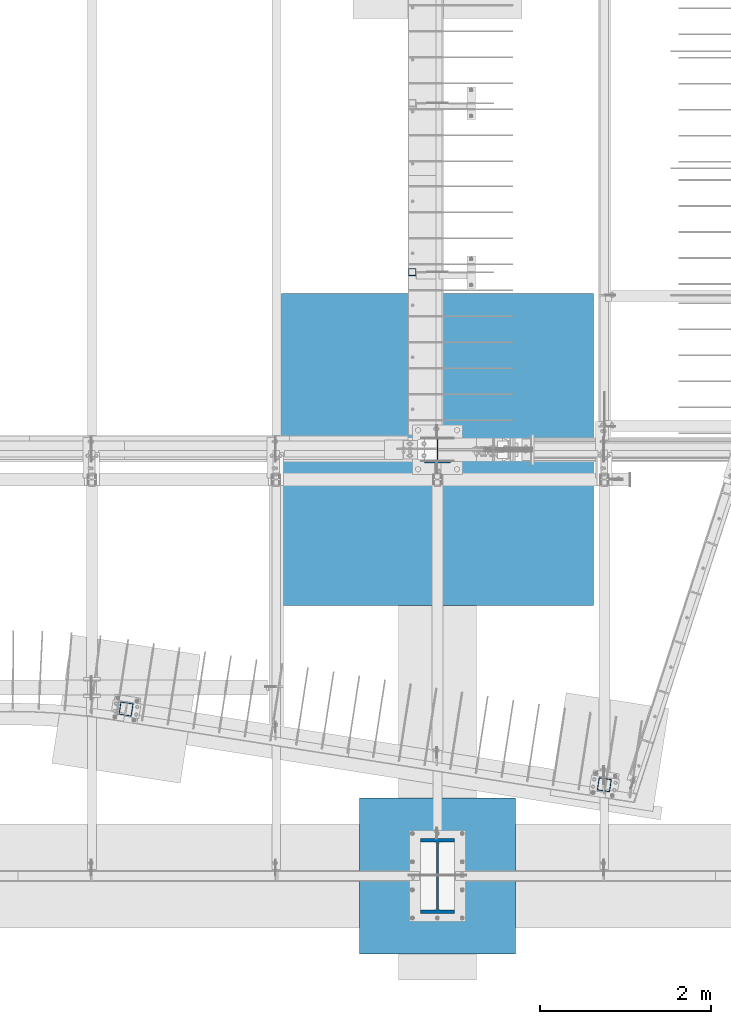
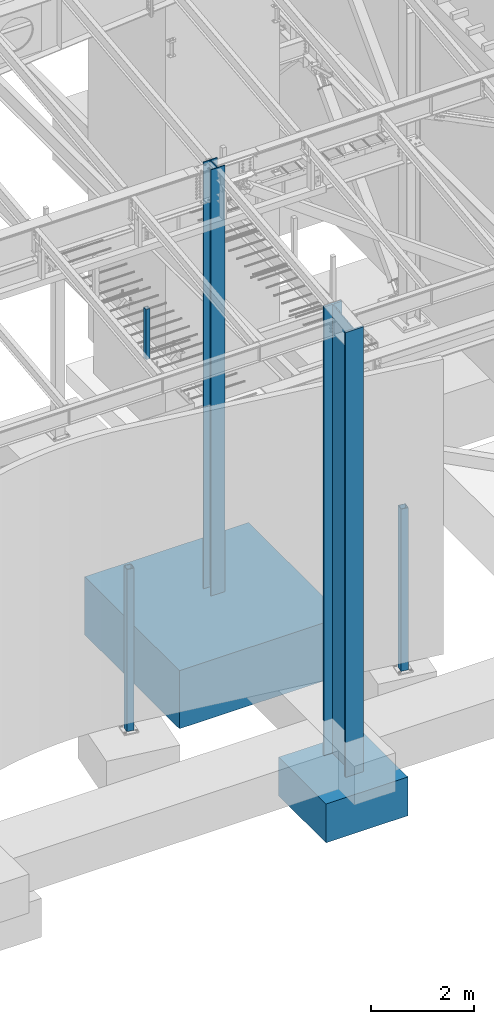
# One storey, part 353 of 1179: 7 columns, 7 elements without a shape of their own.
"""IFC2X3 building model written with IfcOpenShell, lengths in millimetres."""

from ifc_helpers import new_model, si_unit, frame, origin_with_axes, place, context, subcontext, project, spatial, faceted_brep, material, type_object, element, aggregate, save


model = new_model("IFC2X3")

# Units and contexts
model_context = context("Model", 3, precision=1e-05, world=origin_with_axes())
body_context = subcontext(model_context, "Body", "Model", "MODEL_VIEW")
ifc_project = project(units=[si_unit("LENGTHUNIT", "METRE", prefix="MILLI"), si_unit("AREAUNIT", "SQUARE_METRE"), si_unit("VOLUMEUNIT", "CUBIC_METRE"), si_unit("MASSUNIT", "GRAM", prefix="KILO"), si_unit("TIMEUNIT", "SECOND"), si_unit("PLANEANGLEUNIT", "RADIAN"), si_unit("SOLIDANGLEUNIT", "STERADIAN"), si_unit("THERMODYNAMICTEMPERATUREUNIT", "DEGREE_CELSIUS"), si_unit("LUMINOUSINTENSITYUNIT", "LUMEN")], contexts=[model_context])

# Site, building, storey
site_placement = place(None, origin_with_axes())
site = spatial("IfcSite", under=ifc_project, at=site_placement, CompositionType="ELEMENT")
building_placement = place(site_placement, origin_with_axes())
building = spatial("IfcBuilding", under=site, at=building_placement, Name="Undefined", CompositionType="ELEMENT")
storey_placement = place(building_placement, origin_with_axes())
storey = spatial("IfcBuildingStorey", under=building, at=storey_placement, Name="Undefined", CompositionType="ELEMENT", Elevation=0.0)

# Assembly, column
assembly_1_placement = place(storey_placement, origin_with_axes())
assembly_1 = element("IfcElementAssembly", 1, at=assembly_1_placement, inside=storey, Name="COLUMN", AssemblyPlace="NOTDEFINED", PredefinedType="RIGID_FRAME")
ifc_material_1 = material()
column_type_1 = type_object("IfcColumnType", Name="HSS6X6X3/8", PredefinedType="NOTDEFINED")
column_1_placement = place(assembly_1_placement, frame((18414.9999999967, 1508.125, -431.8), z_axis=(0.154376895068654, 0.988012031439376, 0.0), x_axis=(0.0, 0.0, 1.0)))
column_1 = element("IfcColumn", 2, at=column_1_placement, type_object=column_type_1, material=ifc_material_1, Name="COLUMN", ObjectType="HSS6X6X3/8", context=body_context, shape_type="Brep", body=[
    faceted_brep([(76.2000000000008, 66.675000000112, -66.6749999999902), (76.2000000000008, -66.6750000001084, -66.6750000000175), (3902.075, -66.6750000001084, -66.6750000000175), (3902.075, 66.675000000112, -66.6749999999902), (76.2000000000008, -66.6750000001011, 66.674999999992), (3902.075, -66.6750000001011, 66.674999999992), (76.2000000000008, 66.6750000001193, 66.6750000000193), (3902.075, 66.6750000001193, 66.6750000000193), (76.2000000000008, 76.2000000001281, -76.1999999999898), (76.2000000000008, 76.2000000001317, 76.2000000000216), (3902.075, 76.2000000001317, 76.2000000000216), (3902.075, 76.2000000001281, -76.1999999999898), (76.2000000000008, -76.2000000001171, 76.1999999999916), (3902.075, -76.2000000001171, 76.1999999999916), (76.2000000000008, -76.2000000001208, -76.2000000000198), (3902.075, -76.2000000001208, -76.2000000000198)], [[[0, 1, 2, 3]], [[1, 4, 5, 2]], [[4, 6, 7, 5]], [[6, 0, 3, 7]], [[8, 9, 10, 11]], [[9, 12, 13, 10]], [[12, 14, 15, 13]], [[14, 8, 11, 15]], [[13, 15, 11, 10], [5, 7, 3, 2]], [[14, 12, 9, 8], [6, 4, 1, 0]]]),
])
aggregate(assembly_1, [column_1])

assembly_2_placement = place(storey_placement, origin_with_axes())
assembly_2 = element("IfcElementAssembly", 3, at=assembly_2_placement, inside=storey, Name="COLUMN", AssemblyPlace="NOTDEFINED", PredefinedType="RIGID_FRAME")
column_2_placement = place(assembly_2_placement, frame((12807.7262148692, 2395.53442645032, -431.8), z_axis=(0.154376895068654, 0.988012031439376, 0.0), x_axis=(0.0, 0.0, 1.0)))
column_2 = element("IfcColumn", 4, at=column_2_placement, type_object=column_type_1, material=ifc_material_1, Name="COLUMN", ObjectType="HSS6X6X3/8", context=body_context, shape_type="Brep", body=[
    faceted_brep([(76.2000000000008, 66.675000000112, -66.6749999999902), (76.2000000000008, -66.6750000001084, -66.6750000000175), (3902.075, -66.6750000001084, -66.6750000000175), (3902.075, 66.675000000112, -66.6749999999902), (76.2000000000008, -66.6750000001011, 66.674999999992), (3902.075, -66.6750000001011, 66.674999999992), (76.2000000000008, 66.6750000001193, 66.6750000000193), (3902.075, 66.6750000001193, 66.6750000000193), (76.2000000000008, 76.2000000001281, -76.1999999999898), (76.2000000000008, 76.2000000001317, 76.2000000000216), (3902.075, 76.2000000001317, 76.2000000000216), (3902.075, 76.2000000001281, -76.1999999999898), (76.2000000000008, -76.2000000001171, 76.1999999999916), (3902.075, -76.2000000001171, 76.1999999999916), (76.2000000000008, -76.2000000001208, -76.2000000000198), (3902.075, -76.2000000001208, -76.2000000000198)], [[[0, 1, 2, 3]], [[1, 4, 5, 2]], [[4, 6, 7, 5]], [[6, 0, 3, 7]], [[8, 9, 10, 11]], [[9, 12, 13, 10]], [[12, 14, 15, 13]], [[14, 8, 11, 15]], [[13, 15, 11, 10], [5, 7, 3, 2]], [[14, 12, 9, 8], [6, 4, 1, 0]]]),
])
aggregate(assembly_2, [column_2])

assembly_3_placement = place(storey_placement, origin_with_axes())
assembly_3 = element("IfcElementAssembly", 5, at=assembly_3_placement, inside=storey, Name="COLUMN", AssemblyPlace="NOTDEFINED", PredefinedType="RIGID_FRAME")
column_type_2 = type_object("IfcColumnType", Name="HSS3-1/2X3-1/2X5/16", PredefinedType="NOTDEFINED")
column_3_placement = place(assembly_3_placement, frame((16163.925, 7518.40000000001, 4108.45000000003), z_axis=(0.0, 1.0, 0.0), x_axis=(0.0, 0.0, 1.0)))
column_3 = element("IfcColumn", 6, at=column_3_placement, type_object=column_type_2, material=ifc_material_1, Name="COLUMN", ObjectType="HSS3-1/2X3-1/2X5/16", context=body_context, shape_type="Brep", body=[
    faceted_brep([(0.0, 36.5125000000007, -36.5125000000007), (0.0, -36.5125000000007, -36.5125000000007), (1189.03749999998, -36.5125000000007, -36.5124999999998), (1189.03749999998, 36.5125000000007, -36.5124999999998), (0.0, -36.5125000000007, 36.5125000000007), (1189.03749999998, -36.5125000000007, 36.5124999999998), (0.0, 36.5125000000007, 36.5125000000007), (1189.03749999998, 36.5125000000007, 36.5124999999998), (0.0, 44.4500000000007, -44.4499999999998), (0.0, 44.4500000000007, 44.4500000000007), (1189.03749999998, 44.4500000000007, 44.4499999999998), (1189.03749999998, 44.4500000000007, -44.4499999999998), (0.0, -44.4500000000007, 44.4500000000007), (1189.03749999998, -44.4500000000007, 44.4499999999998), (0.0, -44.4500000000007, -44.4500000000007), (1189.03749999998, -44.4500000000007, -44.4499999999998)], [[[0, 1, 2, 3]], [[1, 4, 5, 2]], [[4, 6, 7, 5]], [[6, 0, 3, 7]], [[8, 9, 10, 11]], [[9, 12, 13, 10]], [[12, 14, 15, 13]], [[14, 8, 11, 15]], [[13, 15, 11, 10], [5, 7, 3, 2]], [[14, 12, 9, 8], [6, 4, 1, 0]]]),
])
aggregate(assembly_3, [column_3])

assembly_4_placement = place(storey_placement, origin_with_axes())
assembly_4 = element("IfcElementAssembly", 7, at=assembly_4_placement, inside=storey, Name="FOOTING", AssemblyPlace="NOTDEFINED", PredefinedType="REINFORCEMENT_UNIT")
ifc_material_2 = material(Name="CONCRETE/3000")
column_type_3 = type_object("IfcColumnType", PredefinedType="NOTDEFINED")
column_4_placement = place(assembly_4_placement, frame((16459.2, 438.15, -2260.6), z_axis=(-1.0, 0.0, 0.0), x_axis=(0.0, 0.0, 1.0)))
column_4 = element("IfcColumn", 8, at=column_4_placement, type_object=column_type_3, material=ifc_material_2, Name="FOOTING", context=body_context, shape_type="Brep", body=[
    faceted_brep([(0.0, 914.400000000001, -914.400000000001), (0.0, 914.400000000001, 914.400000000001), (914.4, 914.4, 914.400000000001), (914.4, 914.4, -914.400000000001), (0.0, -914.400000000001, 914.400000000001), (914.4, -914.4, 914.400000000001), (0.0, -914.400000000001, -914.400000000001), (914.4, -914.4, -914.400000000001)], [[[0, 1, 2, 3]], [[1, 4, 5, 2]], [[4, 6, 7, 5]], [[6, 0, 3, 7]], [[5, 7, 3, 2]], [[6, 4, 1, 0]]]),
])
aggregate(assembly_4, [column_4])

assembly_5_placement = place(storey_placement, origin_with_axes())
assembly_5 = element("IfcElementAssembly", 9, at=assembly_5_placement, inside=storey, Name="FOOTING", AssemblyPlace="NOTDEFINED", PredefinedType="REINFORCEMENT_UNIT")
column_type_4 = type_object("IfcColumnType", PredefinedType="NOTDEFINED")
column_5_placement = place(assembly_5_placement, frame((16459.2, 5435.6, -1727.2), z_axis=(-1.0, 0.0, 0.0), x_axis=(0.0, 0.0, 1.0)))
column_5 = element("IfcColumn", 10, at=column_5_placement, type_object=column_type_4, material=ifc_material_2, Name="FOOTING", context=body_context, shape_type="Brep", body=[
    faceted_brep([(0.0, 1828.8, -1828.8), (0.0, 1828.8, 1828.8), (1371.6, 1828.8, 1828.8), (1371.6, 1828.8, -1828.8), (0.0, -1828.8, 1828.8), (1371.6, -1828.8, 1828.8), (0.0, -1828.8, -1828.8), (1371.6, -1828.8, -1828.8)], [[[0, 1, 2, 3]], [[1, 4, 5, 2]], [[4, 6, 7, 5]], [[6, 0, 3, 7]], [[5, 7, 3, 2]], [[6, 4, 1, 0]]]),
])
aggregate(assembly_5, [column_5])

assembly_6_placement = place(storey_placement, origin_with_axes())
assembly_6 = element("IfcElementAssembly", 11, at=assembly_6_placement, inside=storey, Name="COLUMN", AssemblyPlace="NOTDEFINED", PredefinedType="RIGID_FRAME")
ifc_material_3 = material(Name="STEEL/A992")
column_type_5 = type_object("IfcColumnType", Name="W33X263", PredefinedType="NOTDEFINED")
column_6_placement = place(assembly_6_placement, frame((16459.2, 438.15, -1346.2), z_axis=(0.0, 1.0, 0.0), x_axis=(0.0, 0.0, 1.0)))
column_6 = element("IfcColumn", 12, at=column_6_placement, type_object=column_type_5, material=ifc_material_3, Name="COLUMN", ObjectType="W33X263", context=body_context, shape_type="Brep", body=[
    faceted_brep([(88.8999999999999, 200.025000000001, -438.15), (88.8999999999999, 200.025000000001, -398.4625), (10587.9886488325, 200.025000000001, -398.4625), (10583.5040139534, 200.025000000001, -438.15), (88.8999999999999, 11.1124999999993, -398.4625), (10587.9886488325, 11.1124999999993, -398.4625), (88.8999999999999, 11.1124999999993, 398.4625), (10678.0401172034, 11.1124999999993, 398.4625), (88.8999999999999, 200.025000000001, 398.4625), (10678.0401172034, 200.025000000001, 398.4625), (88.8999999999999, 200.025000000001, 438.15), (10682.5247520824, 200.025000000001, 438.15), (88.8999999999999, -200.025000000001, 438.15), (10682.5247520824, -200.025000000001, 438.15), (88.8999999999999, -200.025000000001, 398.4625), (10678.0401172034, -200.025000000001, 398.4625), (88.8999999999999, -11.1124999999993, 398.4625), (10678.0401172034, -11.1124999999993, 398.4625), (88.8999999999999, -11.1124999999993, -398.4625), (10587.9886488325, -11.1124999999993, -398.4625), (88.8999999999999, -200.025000000001, -398.4625), (10587.9886488325, -200.025000000001, -398.4625), (88.8999999999999, -200.025000000001, -438.15), (10583.5040139534, -200.025000000001, -438.15)], [[[0, 1, 2, 3]], [[1, 4, 5, 2]], [[4, 6, 7, 5]], [[6, 8, 9, 7]], [[8, 10, 11, 9]], [[10, 12, 13, 11]], [[12, 14, 15, 13]], [[14, 16, 17, 15]], [[16, 18, 19, 17]], [[18, 20, 21, 19]], [[20, 22, 23, 21]], [[22, 0, 3, 23]], [[5, 7, 9, 11, 13, 15, 17, 19, 21, 23, 3, 2]], [[22, 20, 18, 16, 14, 12, 10, 8, 6, 4, 1, 0]]]),
])
aggregate(assembly_6, [column_6])

assembly_7_placement = place(storey_placement, origin_with_axes())
assembly_7 = element("IfcElementAssembly", 13, at=assembly_7_placement, inside=storey, Name="COLUMN", AssemblyPlace="NOTDEFINED", PredefinedType="RIGID_FRAME")
column_type_6 = type_object("IfcColumnType", Name="W12X79", PredefinedType="NOTDEFINED")
column_7_placement = place(assembly_7_placement, frame((16459.2, 5435.6, -355.6), z_axis=(0.0, 1.0, 0.0), x_axis=(0.0, 0.0, 1.0)))
column_7 = element("IfcColumn", 14, at=column_7_placement, type_object=column_type_6, material=ifc_material_3, Name="COLUMN", ObjectType="W12X79", context=body_context, shape_type="Brep", body=[
    faceted_brep([(160.223581529497, -153.987499999999, 157.1625), (160.223581529497, 153.987499999999, 157.1625), (149.225002356772, 153.987499999999, 138.1125), (149.225002356772, 6.35000012494493, 138.1125), (148.995793121516, 6.35000012313685, 137.715499999996), (148.995793121516, -6.34999999999854, 137.715499999996), (149.225002356772, -6.34999999999854, 138.1125), (149.225002356772, -153.987499999999, 138.1125), (10216.753125, 153.987499999999, -157.1625), (10216.753125, -153.987499999999, -157.1625), (160.223597538519, -153.987499999999, -157.1625), (160.223597538519, 153.987499999999, -157.1625), (10216.753125, -153.987499999999, -138.1125), (149.225402461476, -153.987499999999, -138.1125), (10216.753125, -6.34999999999854, -138.1125), (149.225402461476, -6.34999999999854, -138.1125), (188.913, -6.34999999999854, 137.715499999996), (188.913, 6.35000008947463, 137.715499999996), (208.49066058208, 6.35000008789211, 131.2871410688), (208.49066058208, -6.34999999999854, 131.2871410688), (212.873373738864, 6.35000008718271, 128.290736246858), (212.873373738864, -6.34999999999854, 128.290736246858), (214.971292158606, 6.35000008606585, 123.413713099926), (214.971292158606, -6.34999999999854, 123.413713099926), (214.132634973196, 6.3500000848835, 118.171264187733), (214.132634973196, -6.34999999999854, 118.171264187733), (210.617956026487, 6.35000008400311, 114.192112472459), (210.617956026487, -6.34999999999854, 114.192112472459), (205.519195059062, 6.35000008370116, 112.712499999996), (205.519195059062, -6.34999999999854, 112.712499999996), (139.700000000001, 6.34999999999854, 112.7125), (147.032309983244, -6.35000007376584, 112.7125), (139.700000000001, 6.34999999999854, -112.7125), (147.032309983244, -6.35000000747095, -112.7125), (205.519195059063, 6.3500000365857, -112.712500000003), (205.519195059063, -6.34999999999854, -112.712500000003), (210.617956026486, 6.35000003621826, -114.192112472468), (210.617956026486, -6.34999999999854, -114.192112472468), (214.132634973195, 6.35000003529422, -118.171264187741), (214.132634973195, -6.34999999999854, -118.171264187741), (214.971292158605, 6.35000003410096, -123.413713099934), (214.971292158605, -6.34999999999854, -123.413713099934), (212.873373738863, 6.35000003300956, -128.290736246865), (212.873373738863, -6.34999999999854, -128.290736246865), (208.49066058208, 6.35000003235837, -131.287141068808), (208.49066058208, -6.34999999999854, -131.287141068808), (188.913, 6.35000003102323, -137.715500000003), (188.913, -6.34999999999854, -137.715500000003), (148.99620123074, 6.35000000162472, -137.715500000003), (148.99620123074, -6.34999999999854, -137.715500000003), (10216.753125, 6.34999999999854, -138.1125), (10216.753125, 153.987499999999, -138.1125), (149.225402461476, 153.987499999999, -138.1125), (149.225402461477, 6.34999999999854, -138.1125), (10216.753125, 6.34999999999854, 138.1125), (10216.753125, 153.987499999999, 138.1125), (10216.753125, 153.987499999999, 157.1625), (10216.753125, -153.987499999999, 157.1625), (10216.753125, -153.987499999999, 138.1125), (10216.753125, -6.34999999999854, 138.1125)], [[[0, 1, 2, 3, 4, 5, 6, 7]], [[8, 9, 10, 11]], [[9, 12, 13, 10]], [[12, 14, 15, 13]], [[16, 17, 18, 19]], [[19, 18, 20, 21]], [[21, 20, 22, 23]], [[23, 22, 24, 25]], [[25, 24, 26, 27]], [[27, 26, 28, 29]], [[29, 28, 30, 31]], [[32, 33, 31, 30]], [[33, 32, 34, 35]], [[35, 34, 36, 37]], [[37, 36, 38, 39]], [[39, 38, 40, 41]], [[41, 40, 42, 43]], [[43, 42, 44, 45]], [[45, 44, 46, 47]], [[47, 46, 48, 49]], [[50, 51, 52, 53]], [[10, 13, 15, 49, 48, 53, 52, 11]], [[51, 8, 11, 52]], [[50, 54, 55, 56, 57, 58, 59, 14, 12, 9, 8, 51]], [[58, 57, 0, 7]], [[59, 58, 7, 6]], [[16, 19, 21, 23, 25, 27, 29, 31, 33, 35, 37, 39, 41, 43, 45, 47, 49, 15, 14, 59, 6, 5]], [[17, 16, 5, 4]], [[54, 50, 53, 48, 46, 44, 42, 40, 38, 36, 34, 32, 30, 28, 26, 24, 22, 20, 18, 17, 4, 3]], [[55, 54, 3, 2]], [[56, 55, 2, 1]], [[57, 56, 1, 0]]]),
])
aggregate(assembly_7, [column_7])

save(model, "model.ifc")
